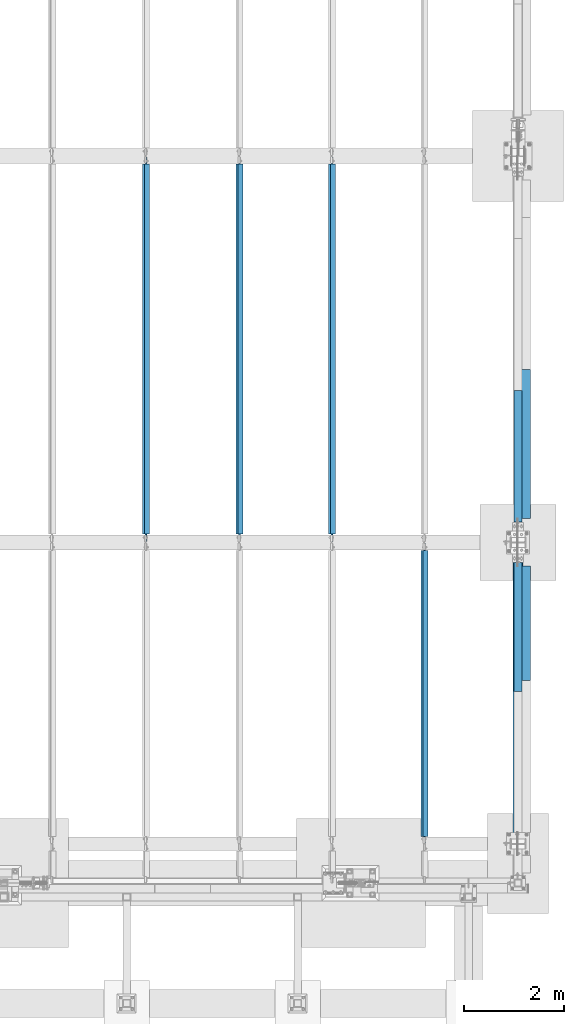
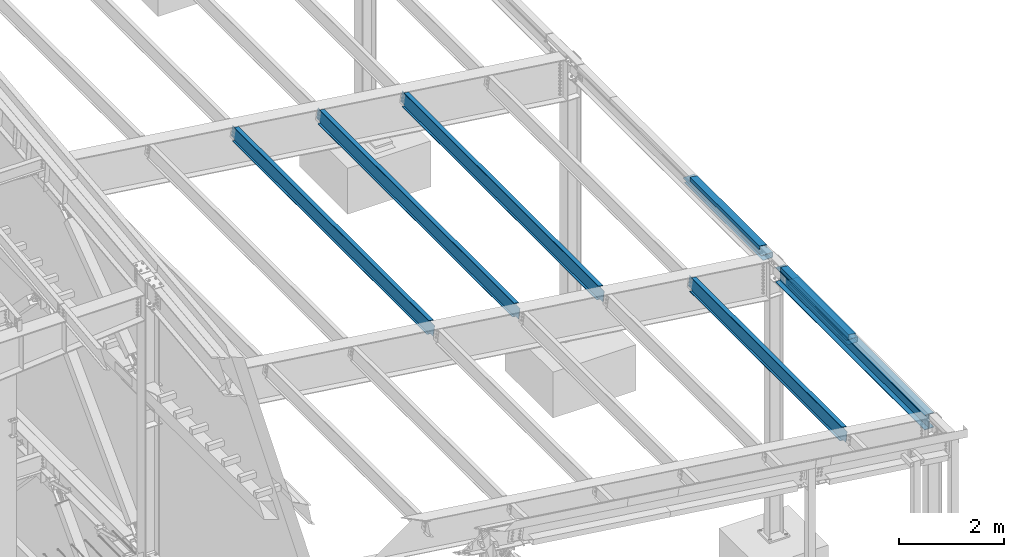
# One storey, part 748 of 1179: 9 beams, 6 elements without a shape of their own.
"""IFC2X3 building model written with IfcOpenShell, lengths in millimetres."""

from ifc_helpers import new_model, si_unit, frame, origin_with_axes, place, context, subcontext, project, spatial, faceted_brep, material, type_object, element, aggregate, save


model = new_model("IFC2X3")

# Units and contexts
model_context = context("Model", 3, precision=1e-05, world=origin_with_axes())
body_context = subcontext(model_context, "Body", "Model", "MODEL_VIEW")
ifc_project = project(units=[si_unit("LENGTHUNIT", "METRE", prefix="MILLI"), si_unit("AREAUNIT", "SQUARE_METRE"), si_unit("VOLUMEUNIT", "CUBIC_METRE"), si_unit("MASSUNIT", "GRAM", prefix="KILO"), si_unit("TIMEUNIT", "SECOND"), si_unit("PLANEANGLEUNIT", "RADIAN"), si_unit("SOLIDANGLEUNIT", "STERADIAN"), si_unit("THERMODYNAMICTEMPERATUREUNIT", "DEGREE_CELSIUS"), si_unit("LUMINOUSINTENSITYUNIT", "LUMEN")], contexts=[model_context])

# Site, building, storey
site_placement = place(None, origin_with_axes())
site = spatial("IfcSite", under=ifc_project, at=site_placement, CompositionType="ELEMENT")
building_placement = place(site_placement, origin_with_axes())
building = spatial("IfcBuilding", under=site, at=building_placement, Name="Undefined", CompositionType="ELEMENT")
storey_placement = place(building_placement, origin_with_axes())
storey = spatial("IfcBuildingStorey", under=building, at=storey_placement, Name="Undefined", CompositionType="ELEMENT", Elevation=0.0)

# Assembly, beam
assembly_1_placement = place(storey_placement, origin_with_axes())
assembly_1 = element("IfcElementAssembly", 1, at=assembly_1_placement, inside=storey, Name="BEAM", AssemblyPlace="NOTDEFINED", PredefinedType="RIGID_FRAME")
ifc_material_1 = material(Name="STEEL/A36")
beam_type_1 = type_object("IfcBeamType", PredefinedType="NOTDEFINED")
beam_1_placement = place(assembly_1_placement, frame((37996.8124994166, 13208.794, 6096.00000000004), z_axis=(0.0, -1.0, 0.0), x_axis=(0.0, 0.0, 1.0)))
beam_1 = element("IfcBeam", 2, at=beam_1_placement, type_object=beam_type_1, material=ifc_material_1, Name="BENT_PLATE", context=body_context, shape_type="Brep", body=[
    faceted_brep([(3.8198777474463e-11, -4.76249999999709, -1323.1815), (3.8198777474463e-11, -4.76249999999709, 1323.1815), (-3.8198777474463e-11, 4.76249999999709, 1323.1815), (-3.8198777474463e-11, 4.76249999999709, -1323.1815), (92.8848876952779, 4.76250000074651, 1323.1815), (92.8848876952779, 4.76250000074651, -1323.1815), (81.9873102930469, -4.76249999933498, -1323.1815), (81.9873102930469, -4.76249999933498, 1323.1815), (70.5918350219381, -160.337506103519, 1323.1815), (70.5918350219381, -160.337506103519, -1323.1815), (62.266532833075, -150.812506103524, -1323.1815), (62.266532833075, -150.812506103524, 1323.1815), (-7.6397554948926e-11, -160.337506103519, 1323.1815), (-7.6397554948926e-11, -160.337506103519, -1323.1815), (-7.6397554948926e-11, -150.812506103524, 1323.1815), (-7.6397554948926e-11, -150.812506103524, -1323.1815)], [[[0, 1, 2, 3]], [[3, 2, 4, 5]], [[1, 0, 6, 7]], [[5, 4, 8, 9]], [[7, 6, 10, 11]], [[9, 8, 12, 13]], [[8, 4, 2, 1, 7, 11, 14, 12]], [[11, 10, 15, 14]], [[10, 6, 0, 3, 5, 9, 13, 15]], [[14, 15, 13, 12]]]),
])

# Assembly, beams
assembly_2_placement = place(storey_placement, origin_with_axes())
assembly_2 = element("IfcElementAssembly", 3, at=assembly_2_placement, inside=storey, Name="BEAM", AssemblyPlace="NOTDEFINED", PredefinedType="RIGID_FRAME")
beam_2_placement = place(assembly_2_placement, frame((37996.8124994167, 9782.17499999974, 6096.00000000004), z_axis=(0.0, -1.0, 0.0), x_axis=(0.0, 0.0, 1.0)))
beam_2 = element("IfcBeam", 4, at=beam_2_placement, type_object=beam_type_1, material=ifc_material_1, Name="BENT_PLATE", context=body_context, shape_type="Brep", body=[
    faceted_brep([(3.8198777474463e-11, -4.76249999999709, -1295.4), (3.8198777474463e-11, -4.76249999999709, 1295.4), (-3.8198777474463e-11, 4.76249999999709, 1295.4), (-3.8198777474463e-11, 4.76249999999709, -1295.4), (92.8848876952779, 4.76250000074651, 1295.4), (92.8848876952779, 4.76250000074651, -1295.4), (81.9873102930469, -4.76249999933498, -1295.4), (81.9873102930469, -4.76249999933498, 1295.4), (70.5918350219381, -160.337506103519, 1295.4), (70.5918350219381, -160.337506103519, -1295.4), (62.266532833075, -150.812506103524, -1295.4), (62.266532833075, -150.812506103524, 1295.4), (-7.6397554948926e-11, -160.337506103519, 1295.4), (-7.6397554948926e-11, -160.337506103519, -1295.4), (-7.6397554948926e-11, -150.812506103524, 1295.4), (-7.6397554948926e-11, -150.812506103524, -1295.4)], [[[0, 1, 2, 3]], [[3, 2, 4, 5]], [[1, 0, 6, 7]], [[5, 4, 8, 9]], [[7, 6, 10, 11]], [[9, 8, 12, 13]], [[8, 4, 2, 1, 7, 11, 14, 12]], [[11, 10, 15, 14]], [[10, 6, 0, 3, 5, 9, 13, 15]], [[14, 15, 13, 12]]]),
])
beam_type_2 = type_object("IfcBeamType", PredefinedType="NOTDEFINED")
beam_3_placement = place(assembly_2_placement, frame((38112.7, 9859.16900000015, 5765.8), z_axis=(0.0, 1.0, 0.0), x_axis=(1.0, 0.0, 0.0)))
beam_3 = element("IfcBeam", 5, at=beam_3_placement, type_object=beam_type_2, material=ifc_material_1, Name="BENT_PLATE", context=body_context, shape_type="Brep", body=[
    faceted_brep([(0.0, -3.17500000000018, -1145.3815), (0.0, -3.17500000000018, 1145.3815), (0.0, 3.17500000000018, 1145.3815), (0.0, 3.17500000000018, -1145.3815), (215.900000000009, 3.17500000000018, 1145.3815), (215.900000000009, 3.17500000000018, -1145.3815), (209.550000000003, -3.17500000000018, -1145.3815), (209.550000000003, -3.17500000000018, 1145.3815), (215.900000000009, -123.825, 1145.3815), (215.900000000009, -123.825, -1145.3815), (209.550000000003, -117.474999999999, -1145.3815), (209.550000000003, -117.474999999999, 1145.3815), (-34.1312499999985, -123.825, 1145.3815), (-34.1312499999985, -123.825, -1145.3815), (-34.1312499999985, -117.474999999999, 1145.3815), (-34.1312499999985, -117.474999999999, -1145.3815)], [[[0, 1, 2, 3]], [[3, 2, 4, 5]], [[1, 0, 6, 7]], [[5, 4, 8, 9]], [[7, 6, 10, 11]], [[9, 8, 12, 13]], [[8, 4, 2, 1, 7, 11, 14, 12]], [[11, 10, 15, 14]], [[10, 6, 0, 3, 5, 9, 13, 15]], [[14, 15, 13, 12]]]),
])

# Beam
beam_4_placement = place(assembly_1_placement, frame((38112.7, 13454.0625000003, 5765.8), z_axis=(0.0, 1.0, 0.0), x_axis=(1.0, 0.0, 0.0)))
beam_4 = element("IfcBeam", 6, at=beam_4_placement, type_object=beam_type_2, material=ifc_material_1, Name="BENT_PLATE", context=body_context, shape_type="Brep", body=[
    faceted_brep([(0.0, -3.17500000000018, -1498.6), (0.0, -3.17500000000018, 1498.6), (0.0, 3.17500000000018, 1498.6), (0.0, 3.17500000000018, -1498.6), (215.900000000009, 3.17500000000018, 1498.6), (215.900000000009, 3.17500000000018, -1498.6), (209.550000000003, -3.17500000000018, -1498.6), (209.550000000003, -3.17500000000018, 1498.6), (215.900000000009, -123.825, 1498.6), (215.900000000009, -123.825, -1498.6), (209.550000000003, -117.474999999999, -1498.6), (209.550000000003, -117.474999999999, 1498.6), (-34.1312499999985, -123.825, 1498.6), (-34.1312499999985, -123.825, -1498.6), (-34.1312499999985, -117.474999999999, 1498.6), (-34.1312499999985, -117.474999999999, -1498.6)], [[[0, 1, 2, 3]], [[3, 2, 4, 5]], [[1, 0, 6, 7]], [[5, 4, 8, 9]], [[7, 6, 10, 11]], [[9, 8, 12, 13]], [[8, 4, 2, 1, 7, 11, 14, 12]], [[11, 10, 15, 14]], [[10, 6, 0, 3, 5, 9, 13, 15]], [[14, 15, 13, 12]]]),
])

aggregate(assembly_1, [beam_4, beam_1])

# Assembly, beam
assembly_3_placement = place(storey_placement, origin_with_axes())
assembly_3 = element("IfcElementAssembly", 7, at=assembly_3_placement, inside=storey, Name="BEAM", AssemblyPlace="NOTDEFINED", PredefinedType="RIGID_FRAME")
ifc_material_2 = material(Name="STEEL/A992")
beam_type_3 = type_object("IfcBeamType", Name="W12X22", PredefinedType="NOTDEFINED")
beam_5_placement = place(assembly_3_placement, frame((36199.5820076836, 5435.6, 6273.9306654382), z_axis=(0.133813223953133, 0.0, 0.991006569652931), x_axis=(0.0, 1.0, 0.0)))
beam_5 = element("IfcBeam", 8, at=beam_5_placement, type_object=beam_type_3, material=ifc_material_2, Name="BEAM", ObjectType="W12X22", context=body_context, shape_type="Brep", body=[
    faceted_brep([(5880.09999999999, -3.17499999983193, -144.462500000051), (5880.09999999999, -50.7999999998428, -144.462500000063), (5880.09999999999, -50.7999999998283, -155.575000000068), (5880.09999999999, 50.8000000001921, -155.575000000041), (5880.09999999999, 50.8000000001848, -144.462500000036), (5880.09999999999, 3.17500000017026, -144.462500000049), (5880.09999999999, 3.17500000016298, -136.52499982221), (5880.09999999999, -3.17499999983556, -136.524999822204), (5881.06672992258, 3.17500000015571, -131.66492030416), (5881.06672992258, -3.17499999984648, -131.664920304156), (5883.81974382306, 3.17500000015207, -127.544743836002), (5883.81974382306, -3.17499999985012, -127.544743835997), (5887.93992029121, 3.17500000014843, -124.791729935519), (5887.93992029121, -3.17499999985375, -124.791729935516), (5892.79999980926, 3.17500000014843, -123.825000012932), (5892.79999980926, -3.17499999985375, -123.825000012926), (6024.5625, -3.17499999985375, -123.825000012823), (6024.5625, 3.17500000014479, -123.825000012814), (144.4625, 3.17499999983193, 144.462500000049), (144.4625, 50.7999999998428, 144.462500000061), (5880.09999999999, 50.7999999998428, 144.462500000061), (5880.09999999999, 3.17499999983193, 144.462500000049), (146.049999999999, -3.1749999998392, -136.524999805057), (146.049999999999, 3.17500000015934, -136.52499980506), (146.049999999999, 3.17500000017026, -144.462500000049), (146.049999999999, 50.8000000001848, -144.462500000036), (146.049999999999, 50.8000000001921, -155.575000000041), (146.049999999999, -50.7999999998283, -155.575000000068), (146.049999999999, -50.7999999998428, -144.462500000063), (146.049999999999, -3.17499999983193, -144.462500000051), (145.083270077412, -3.17499999984284, -131.664920287005), (145.083270077412, 3.17500000015571, -131.664920287008), (142.330256176933, -3.17499999985012, -127.544743818849), (142.330256176933, 3.17500000015207, -127.544743818851), (138.21007970878, -3.17499999985375, -124.791729918366), (138.21007970878, 3.17500000014479, -124.791729918372), (133.350000190734, -3.17499999985375, -123.824999995779), (133.350000190734, 3.17500000014843, -123.824999995781), (19.0500000000002, -3.17499999985375, -123.824999995893), (19.0500000000002, 3.17500000014843, -123.824999995886), (19.0500000000002, -3.17500000013752, 117.475000004351), (19.0500000000002, 3.17499999986467, 117.475000004359), (131.762500190734, -3.17500000013752, 117.47500000447), (131.762500190734, 3.17499999986467, 117.475000004464), (136.62257970878, -3.17500000013752, 118.441729927057), (136.62257970878, 3.17499999986103, 118.441729927054), (140.742756176934, -3.17500000014115, 121.194743827538), (140.742756176934, 3.17499999986103, 121.194743827535), (143.495770077412, -3.17500000014479, 125.314920295696), (143.495770077412, 3.17499999985375, 125.314920295692), (144.4625, -3.17500000015571, 130.174999813746), (144.4625, 3.17499999984648, 130.174999813742), (144.4625, -50.8000000001921, 155.575000000039), (144.4625, 50.7999999998283, 155.575000000066), (144.4625, -3.17500000016662, 144.462500000047), (144.4625, -50.8000000001812, 144.462500000034), (5880.09999999999, -3.17500000016662, 144.462500000047), (5880.09999999999, -50.8000000001812, 144.462500000034), (5880.09999999999, -50.8000000001921, 155.575000000039), (5880.09999999999, 50.7999999998283, 155.575000000066), (5880.09999999999, -3.17500000015207, 130.17499979644), (5880.09999999999, 3.17499999985012, 130.174999796436), (5881.06672992258, -3.17500000014843, 125.314920278392), (5881.06672992258, 3.17499999985012, 125.314920278386), (5883.81974382306, -3.17500000014479, 121.194743810232), (5883.81974382306, 3.17499999985739, 121.194743810229), (5887.93992029121, -3.17500000013752, 118.441729909751), (5887.93992029121, 3.17499999986103, 118.441729909748), (5892.79999980926, -3.17500000013752, 117.474999987164), (5892.79999980926, 3.17499999986467, 117.474999987158), (6024.5625, -3.17500000013752, 117.474999987267), (6024.5625, 3.17499999986467, 117.474999987275)], [[[0, 1, 2, 3, 4, 5, 6, 7]], [[7, 6, 8, 9]], [[9, 8, 10, 11]], [[11, 10, 12, 13]], [[13, 12, 14, 15]], [[16, 15, 14, 17]], [[18, 19, 20, 21]], [[22, 23, 24, 25, 26, 27, 28, 29]], [[30, 31, 23, 22]], [[32, 33, 31, 30]], [[34, 35, 33, 32]], [[36, 37, 35, 34]], [[38, 39, 37, 36]], [[40, 41, 39, 38]], [[42, 43, 41, 40]], [[44, 45, 43, 42]], [[46, 47, 45, 44]], [[48, 49, 47, 46]], [[50, 51, 49, 48]], [[52, 53, 19, 18, 51, 50, 54, 55]], [[55, 54, 56, 57]], [[52, 55, 57, 58]], [[53, 52, 58, 59]], [[19, 53, 59, 20]], [[58, 57, 56, 60, 61, 21, 20, 59]], [[62, 63, 61, 60]], [[64, 65, 63, 62]], [[66, 67, 65, 64]], [[68, 69, 67, 66]], [[70, 71, 69, 68]], [[71, 70, 16, 17]], [[12, 10, 8, 6, 5, 24, 23, 31, 33, 35, 37, 39, 41, 43, 45, 47, 49, 51, 18, 21, 61, 63, 65, 67, 69, 71, 17, 14]], [[25, 24, 5, 4]], [[26, 25, 4, 3]], [[27, 26, 3, 2]], [[28, 27, 2, 1]], [[29, 28, 1, 0]], [[70, 68, 66, 64, 62, 60, 56, 54, 50, 48, 46, 44, 42, 40, 38, 36, 34, 32, 30, 22, 29, 0, 7, 9, 11, 13, 15, 16]]]),
])
aggregate(assembly_3, [beam_5])

assembly_4_placement = place(storey_placement, origin_with_axes())
assembly_4 = element("IfcElementAssembly", 9, at=assembly_4_placement, inside=storey, Name="BEAM", AssemblyPlace="NOTDEFINED", PredefinedType="RIGID_FRAME")
beam_6_placement = place(assembly_4_placement, frame((34345.3820076476, 11480.8, 6524.29881517188), z_axis=(0.133813223953133, 0.0, 0.991006569652931), x_axis=(0.0, 1.0, 0.0)))
beam_6 = element("IfcBeam", 10, at=beam_6_placement, type_object=beam_type_3, material=ifc_material_2, Name="BEAM", ObjectType="W12X22", context=body_context, shape_type="Brep", body=[
    faceted_brep([(7585.075, -3.17499999982829, -144.462500000047), (7585.075, -50.7999999998428, -144.46250000006), (7585.075, -50.7999999998356, -155.575000000064), (7585.075, 50.8000000001921, -155.575000000037), (7585.075, 50.8000000001775, -144.462500000032), (7585.075, 3.17500000017026, -144.462500000047), (7585.075, 3.17500000016298, -136.524999801413), (7585.075, -3.17499999984284, -136.52499980141), (7586.04172992259, 3.17500000014843, -131.664920283363), (7586.04172992259, -3.17499999984284, -131.66492028336), (7588.79474382307, 3.17500000014843, -127.544743815206), (7588.79474382307, -3.17499999985012, -127.544743815202), (7592.91492029122, 3.17500000014843, -124.791729914725), (7592.91492029122, -3.17499999985012, -124.791729914721), (7597.77499980927, 3.17500000014115, -123.824999992135), (7597.77499980927, -3.17499999985739, -123.824999992132), (7726.3625, -3.17499999985739, -123.824999992028), (7726.3625, 3.17500000014115, -123.824999992019), (165.100000000002, 3.17499999982829, 144.462500000052), (165.100000000002, 50.7999999998356, 144.462500000065), (7585.075, 50.7999999998356, 144.462500000065), (7585.075, 3.17499999982829, 144.462500000052), (165.100000000002, -3.17499999984284, -136.524999799762), (165.100000000002, 3.17500000016298, -136.524999799765), (165.100000000002, 3.17500000017026, -144.462500000047), (165.100000000002, 50.8000000001775, -144.462500000032), (165.100000000002, 50.8000000001921, -155.575000000037), (165.100000000002, -50.7999999998356, -155.575000000064), (165.100000000002, -50.7999999998428, -144.46250000006), (165.100000000002, -3.17499999982829, -144.462500000047), (164.133270077415, -3.17499999984284, -131.664920281712), (164.133270077415, 3.17500000014843, -131.664920281715), (161.380256176937, -3.17499999985739, -127.544743813552), (161.380256176937, 3.17500000014843, -127.544743813558), (157.260079708783, -3.17499999985739, -124.791729913073), (157.260079708783, 3.17500000014115, -124.791729913077), (152.400000190737, -3.17499999985739, -123.824999990484), (152.400000190737, 3.17500000014843, -123.824999990487), (20.6375000000044, -3.17499999985739, -123.824999990466), (20.6375000000044, 3.17500000014843, -123.824999990458), (20.6375000000044, -3.17500000014115, 117.475000009781), (20.6375000000044, 3.17499999986467, 117.475000009788), (152.400000190737, -3.17500000014115, 117.475000009763), (152.400000190737, 3.17499999985739, 117.475000009759), (157.260079708783, -3.17500000014115, 118.44172993235), (157.260079708783, 3.17499999986467, 118.441729932347), (161.380256176937, -3.17500000014115, 121.194743832832), (161.380256176937, 3.17499999985739, 121.194743832826), (164.133270077415, -3.17500000014843, 125.314920300991), (164.133270077415, 3.17499999985012, 125.314920300985), (165.100000000002, -3.17500000016298, 130.174999819041), (165.100000000002, 3.17499999984284, 130.174999819037), (165.100000000002, -50.8000000001994, 155.575000000043), (165.100000000002, 50.7999999998283, 155.57500000007), (165.100000000002, -3.17500000017753, 144.462500000051), (165.100000000002, -50.8000000001775, 144.462500000036), (7585.075, -3.17500000017753, 144.462500000051), (7585.075, -50.8000000001775, 144.462500000036), (7585.075, -50.8000000001994, 155.575000000043), (7585.075, 50.7999999998283, 155.57500000007), (7585.075, -3.17500000015571, 130.174999817393), (7585.075, 3.17499999985012, 130.174999817389), (7586.04172992259, -3.17500000015571, 125.314920299345), (7586.04172992259, 3.17499999985012, 125.314920299339), (7588.79474382307, -3.17500000014843, 121.194743831185), (7588.79474382307, 3.17499999985739, 121.194743831182), (7592.91492029122, -3.17500000014115, 118.441729930704), (7592.91492029122, 3.17499999986467, 118.441729930701), (7597.77499980927, -3.17500000014115, 117.475000008117), (7597.77499980927, 3.17499999986467, 117.475000008111), (7726.3625, -3.17500000014115, 117.47500000822), (7726.3625, 3.17499999985739, 117.475000008229)], [[[0, 1, 2, 3, 4, 5, 6, 7]], [[7, 6, 8, 9]], [[9, 8, 10, 11]], [[11, 10, 12, 13]], [[13, 12, 14, 15]], [[16, 15, 14, 17]], [[18, 19, 20, 21]], [[22, 23, 24, 25, 26, 27, 28, 29]], [[30, 31, 23, 22]], [[32, 33, 31, 30]], [[34, 35, 33, 32]], [[36, 37, 35, 34]], [[38, 39, 37, 36]], [[40, 41, 39, 38]], [[42, 43, 41, 40]], [[44, 45, 43, 42]], [[46, 47, 45, 44]], [[48, 49, 47, 46]], [[50, 51, 49, 48]], [[52, 53, 19, 18, 51, 50, 54, 55]], [[55, 54, 56, 57]], [[52, 55, 57, 58]], [[53, 52, 58, 59]], [[19, 53, 59, 20]], [[58, 57, 56, 60, 61, 21, 20, 59]], [[62, 63, 61, 60]], [[64, 65, 63, 62]], [[66, 67, 65, 64]], [[68, 69, 67, 66]], [[70, 71, 69, 68]], [[71, 70, 16, 17]], [[12, 10, 8, 6, 5, 24, 23, 31, 33, 35, 37, 39, 41, 43, 45, 47, 49, 51, 18, 21, 61, 63, 65, 67, 69, 71, 17, 14]], [[25, 24, 5, 4]], [[26, 25, 4, 3]], [[27, 26, 3, 2]], [[28, 27, 2, 1]], [[29, 28, 1, 0]], [[70, 68, 66, 64, 62, 60, 56, 54, 50, 48, 46, 44, 42, 40, 38, 36, 34, 32, 30, 22, 29, 0, 7, 9, 11, 13, 15, 16]]]),
])
aggregate(assembly_4, [beam_6])

assembly_5_placement = place(storey_placement, origin_with_axes())
assembly_5 = element("IfcElementAssembly", 11, at=assembly_5_placement, inside=storey, Name="BEAM", AssemblyPlace="NOTDEFINED", PredefinedType="RIGID_FRAME")
beam_7_placement = place(assembly_5_placement, frame((32491.1820076481, 11480.8, 6774.66696326265), z_axis=(0.133813223953133, 0.0, 0.991006569652931), x_axis=(0.0, 1.0, 0.0)))
beam_7 = element("IfcBeam", 12, at=beam_7_placement, type_object=beam_type_3, material=ifc_material_2, Name="BEAM", ObjectType="W12X22", context=body_context, shape_type="Brep", body=[
    faceted_brep([(7585.075, -3.17499999982829, -144.462500000047), (7585.075, -50.7999999998428, -144.46250000006), (7585.075, -50.7999999998356, -155.575000000064), (7585.075, 50.8000000001921, -155.575000000037), (7585.075, 50.8000000001775, -144.462500000032), (7585.075, 3.17500000017026, -144.462500000047), (7585.075, 3.17500000016298, -136.524999801413), (7585.075, -3.17499999984284, -136.52499980141), (7586.04172992259, 3.17500000014843, -131.664920283363), (7586.04172992259, -3.17499999984284, -131.66492028336), (7588.79474382307, 3.17500000014843, -127.544743815206), (7588.79474382307, -3.17499999985012, -127.544743815202), (7592.91492029122, 3.17500000014843, -124.791729914725), (7592.91492029122, -3.17499999985012, -124.791729914721), (7597.77499980927, 3.17500000014115, -123.824999992135), (7597.77499980927, -3.17499999985739, -123.824999992132), (7726.3625, -3.17499999985739, -123.824999992028), (7726.3625, 3.17500000014115, -123.824999992019), (165.100000000002, 3.17499999982829, 144.462500000052), (165.100000000002, 50.7999999998356, 144.462500000065), (7585.075, 50.7999999998356, 144.462500000065), (7585.075, 3.17499999982829, 144.462500000052), (165.100000000002, -3.17499999984284, -136.524999799762), (165.100000000002, 3.17500000016298, -136.524999799765), (165.100000000002, 3.17500000017026, -144.462500000047), (165.100000000002, 50.8000000001775, -144.462500000032), (165.100000000002, 50.8000000001921, -155.575000000037), (165.100000000002, -50.7999999998356, -155.575000000064), (165.100000000002, -50.7999999998428, -144.46250000006), (165.100000000002, -3.17499999982829, -144.462500000047), (164.133270077415, -3.17499999984284, -131.664920281712), (164.133270077415, 3.17500000014843, -131.664920281715), (161.380256176937, -3.17499999985739, -127.544743813552), (161.380256176937, 3.17500000014843, -127.544743813558), (157.260079708783, -3.17499999985739, -124.791729913073), (157.260079708783, 3.17500000014115, -124.791729913077), (152.400000190737, -3.17499999985739, -123.824999990484), (152.400000190737, 3.17500000014843, -123.824999990487), (20.6375000000044, -3.17499999985739, -123.824999990466), (20.6375000000044, 3.17500000014843, -123.824999990458), (20.6375000000044, -3.17500000014115, 117.475000009781), (20.6375000000044, 3.17499999986467, 117.475000009788), (152.400000190737, -3.17500000014115, 117.475000009763), (152.400000190737, 3.17499999985739, 117.475000009759), (157.260079708783, -3.17500000014115, 118.44172993235), (157.260079708783, 3.17499999986467, 118.441729932347), (161.380256176937, -3.17500000014115, 121.194743832832), (161.380256176937, 3.17499999985739, 121.194743832826), (164.133270077415, -3.17500000014843, 125.314920300991), (164.133270077415, 3.17499999985012, 125.314920300985), (165.100000000002, -3.17500000016298, 130.174999819041), (165.100000000002, 3.17499999984284, 130.174999819037), (165.100000000002, -50.8000000001994, 155.575000000043), (165.100000000002, 50.7999999998283, 155.57500000007), (165.100000000002, -3.17500000017753, 144.462500000051), (165.100000000002, -50.8000000001775, 144.462500000036), (7585.075, -3.17500000017753, 144.462500000051), (7585.075, -50.8000000001775, 144.462500000036), (7585.075, -50.8000000001994, 155.575000000043), (7585.075, 50.7999999998283, 155.57500000007), (7585.075, -3.17500000015571, 130.174999817393), (7585.075, 3.17499999985012, 130.174999817389), (7586.04172992259, -3.17500000015571, 125.314920299345), (7586.04172992259, 3.17499999985012, 125.314920299339), (7588.79474382307, -3.17500000014843, 121.194743831185), (7588.79474382307, 3.17499999985739, 121.194743831182), (7592.91492029122, -3.17500000014115, 118.441729930704), (7592.91492029122, 3.17499999986467, 118.441729930701), (7597.77499980927, -3.17500000014115, 117.475000008117), (7597.77499980927, 3.17499999986467, 117.475000008111), (7726.3625, -3.17500000014115, 117.47500000822), (7726.3625, 3.17499999985739, 117.475000008229)], [[[0, 1, 2, 3, 4, 5, 6, 7]], [[7, 6, 8, 9]], [[9, 8, 10, 11]], [[11, 10, 12, 13]], [[13, 12, 14, 15]], [[16, 15, 14, 17]], [[18, 19, 20, 21]], [[22, 23, 24, 25, 26, 27, 28, 29]], [[30, 31, 23, 22]], [[32, 33, 31, 30]], [[34, 35, 33, 32]], [[36, 37, 35, 34]], [[38, 39, 37, 36]], [[40, 41, 39, 38]], [[42, 43, 41, 40]], [[44, 45, 43, 42]], [[46, 47, 45, 44]], [[48, 49, 47, 46]], [[50, 51, 49, 48]], [[52, 53, 19, 18, 51, 50, 54, 55]], [[55, 54, 56, 57]], [[52, 55, 57, 58]], [[53, 52, 58, 59]], [[19, 53, 59, 20]], [[58, 57, 56, 60, 61, 21, 20, 59]], [[62, 63, 61, 60]], [[64, 65, 63, 62]], [[66, 67, 65, 64]], [[68, 69, 67, 66]], [[70, 71, 69, 68]], [[71, 70, 16, 17]], [[12, 10, 8, 6, 5, 24, 23, 31, 33, 35, 37, 39, 41, 43, 45, 47, 49, 51, 18, 21, 61, 63, 65, 67, 69, 71, 17, 14]], [[25, 24, 5, 4]], [[26, 25, 4, 3]], [[27, 26, 3, 2]], [[28, 27, 2, 1]], [[29, 28, 1, 0]], [[70, 68, 66, 64, 62, 60, 56, 54, 50, 48, 46, 44, 42, 40, 38, 36, 34, 32, 30, 22, 29, 0, 7, 9, 11, 13, 15, 16]]]),
])
aggregate(assembly_5, [beam_7])

assembly_6_placement = place(storey_placement, origin_with_axes())
assembly_6 = element("IfcElementAssembly", 13, at=assembly_6_placement, inside=storey, Name="BEAM", AssemblyPlace="NOTDEFINED", PredefinedType="RIGID_FRAME")
beam_8_placement = place(assembly_6_placement, frame((30611.5820076509, 11480.8, 7028.4648120121), z_axis=(0.133813223953133, 0.0, 0.991006569652931), x_axis=(0.0, 1.0, 0.0)))
beam_8 = element("IfcBeam", 14, at=beam_8_placement, type_object=beam_type_3, material=ifc_material_2, Name="BEAM", ObjectType="W12X22", context=body_context, shape_type="Brep", body=[
    faceted_brep([(7585.075, -3.17499999982829, -144.462500000047), (7585.075, -50.7999999998428, -144.46250000006), (7585.075, -50.7999999998356, -155.575000000064), (7585.075, 50.8000000001921, -155.575000000037), (7585.075, 50.8000000001775, -144.462500000032), (7585.075, 3.17500000017026, -144.462500000047), (7585.075, 3.17500000016298, -136.524999801413), (7585.075, -3.17499999984284, -136.52499980141), (7586.04172992259, 3.17500000014843, -131.664920283363), (7586.04172992259, -3.17499999984284, -131.66492028336), (7588.79474382307, 3.17500000014843, -127.544743815206), (7588.79474382307, -3.17499999985012, -127.544743815202), (7592.91492029122, 3.17500000014843, -124.791729914725), (7592.91492029122, -3.17499999985012, -124.791729914721), (7597.77499980927, 3.17500000014115, -123.824999992135), (7597.77499980927, -3.17499999985739, -123.824999992132), (7726.3625, -3.17499999985739, -123.824999992028), (7726.3625, 3.17500000014115, -123.824999992019), (165.100000000002, 3.17499999982829, 144.462500000052), (165.100000000002, 50.7999999998356, 144.462500000065), (7585.075, 50.7999999998356, 144.462500000065), (7585.075, 3.17499999982829, 144.462500000052), (165.100000000002, -3.17499999984284, -136.524999799762), (165.100000000002, 3.17500000016298, -136.524999799765), (165.100000000002, 3.17500000017026, -144.462500000047), (165.100000000002, 50.8000000001775, -144.462500000032), (165.100000000002, 50.8000000001921, -155.575000000037), (165.100000000002, -50.7999999998356, -155.575000000064), (165.100000000002, -50.7999999998428, -144.46250000006), (165.100000000002, -3.17499999982829, -144.462500000047), (164.133270077415, -3.17499999984284, -131.664920281712), (164.133270077415, 3.17500000014843, -131.664920281715), (161.380256176937, -3.17499999985739, -127.544743813552), (161.380256176937, 3.17500000014843, -127.544743813558), (157.260079708783, -3.17499999985739, -124.791729913073), (157.260079708783, 3.17500000014115, -124.791729913077), (152.400000190737, -3.17499999985739, -123.824999990484), (152.400000190737, 3.17500000014843, -123.824999990487), (20.6375000000044, -3.17499999985739, -123.824999990466), (20.6375000000044, 3.17500000014843, -123.824999990458), (20.6375000000044, -3.17500000014115, 117.475000009781), (20.6375000000044, 3.17499999986467, 117.475000009788), (152.400000190737, -3.17500000014115, 117.475000009763), (152.400000190737, 3.17499999985739, 117.475000009759), (157.260079708783, -3.17500000014115, 118.44172993235), (157.260079708783, 3.17499999986467, 118.441729932347), (161.380256176937, -3.17500000014115, 121.194743832832), (161.380256176937, 3.17499999985739, 121.194743832826), (164.133270077415, -3.17500000014843, 125.314920300991), (164.133270077415, 3.17499999985012, 125.314920300985), (165.100000000002, -3.17500000016298, 130.174999819041), (165.100000000002, 3.17499999984284, 130.174999819037), (165.100000000002, -50.8000000001994, 155.575000000043), (165.100000000002, 50.7999999998283, 155.57500000007), (165.100000000002, -3.17500000017753, 144.462500000051), (165.100000000002, -50.8000000001775, 144.462500000036), (7585.075, -3.17500000017753, 144.462500000051), (7585.075, -50.8000000001775, 144.462500000036), (7585.075, -50.8000000001994, 155.575000000043), (7585.075, 50.7999999998283, 155.57500000007), (7585.075, -3.17500000015571, 130.174999817393), (7585.075, 3.17499999985012, 130.174999817389), (7586.04172992259, -3.17500000015571, 125.314920299345), (7586.04172992259, 3.17499999985012, 125.314920299339), (7588.79474382307, -3.17500000014843, 121.194743831185), (7588.79474382307, 3.17499999985739, 121.194743831182), (7592.91492029122, -3.17500000014115, 118.441729930704), (7592.91492029122, 3.17499999986467, 118.441729930701), (7597.77499980927, -3.17500000014115, 117.475000008117), (7597.77499980927, 3.17499999986467, 117.475000008111), (7726.3625, -3.17500000014115, 117.47500000822), (7726.3625, 3.17499999985739, 117.475000008229)], [[[0, 1, 2, 3, 4, 5, 6, 7]], [[7, 6, 8, 9]], [[9, 8, 10, 11]], [[11, 10, 12, 13]], [[13, 12, 14, 15]], [[16, 15, 14, 17]], [[18, 19, 20, 21]], [[22, 23, 24, 25, 26, 27, 28, 29]], [[30, 31, 23, 22]], [[32, 33, 31, 30]], [[34, 35, 33, 32]], [[36, 37, 35, 34]], [[38, 39, 37, 36]], [[40, 41, 39, 38]], [[42, 43, 41, 40]], [[44, 45, 43, 42]], [[46, 47, 45, 44]], [[48, 49, 47, 46]], [[50, 51, 49, 48]], [[52, 53, 19, 18, 51, 50, 54, 55]], [[55, 54, 56, 57]], [[52, 55, 57, 58]], [[53, 52, 58, 59]], [[19, 53, 59, 20]], [[58, 57, 56, 60, 61, 21, 20, 59]], [[62, 63, 61, 60]], [[64, 65, 63, 62]], [[66, 67, 65, 64]], [[68, 69, 67, 66]], [[70, 71, 69, 68]], [[71, 70, 16, 17]], [[12, 10, 8, 6, 5, 24, 23, 31, 33, 35, 37, 39, 41, 43, 45, 47, 49, 51, 18, 21, 61, 63, 65, 67, 69, 71, 17, 14]], [[25, 24, 5, 4]], [[26, 25, 4, 3]], [[27, 26, 3, 2]], [[28, 27, 2, 1]], [[29, 28, 1, 0]], [[70, 68, 66, 64, 62, 60, 56, 54, 50, 48, 46, 44, 42, 40, 38, 36, 34, 32, 30, 22, 29, 0, 7, 9, 11, 13, 15, 16]]]),
])
aggregate(assembly_6, [beam_8])

# Beam
beam_type_4 = type_object("IfcBeamType", Name="W14X48", PredefinedType="NOTDEFINED")
beam_9_placement = place(assembly_2_placement, frame((38074.6, 5435.6, 5921.375), z_axis=(0.0, 0.0, 1.0), x_axis=(0.0, 1.0, 0.0)))
beam_9 = element("IfcBeam", 15, at=beam_9_placement, type_object=beam_type_4, material=ifc_material_2, Name="BEAM", ObjectType="W14X48", context=body_context, shape_type="Brep", body=[
    faceted_brep([(115.887499999999, -101.599999999999, -174.625), (115.887499999999, 101.599999999999, -174.625), (5799.1375, 101.599999999999, -174.625), (5799.1375, -101.599999999999, -174.625), (115.887499999999, -101.599999999999, -158.75), (115.887499999999, -3.96875, -158.75), (115.887499999999, -3.96875, 158.75), (115.887499999999, -101.599999999999, 158.75), (115.887499999999, -101.599999999999, 174.625), (115.887499999999, 101.599999999999, 174.625), (115.887499999999, 101.599999999999, 158.75), (115.887499999999, 3.96875, 158.75), (115.887499999999, 3.96875, 137.265000000093), (115.887499999999, 3.96875, -92.8149999999832), (115.887499999999, 3.96875, -158.75), (115.887499999999, 101.599999999999, -158.75), (5799.1375, -101.599999999999, -158.75), (5799.1375, -3.96875, -158.75), (5799.1375, -3.96875, 158.75), (5799.1375, -101.599999999999, 158.75), (5799.1375, -101.599999999999, 174.625), (5799.1375, 101.599999999999, 174.625), (5799.1375, 101.599999999999, 158.75), (5799.1375, 3.96875, 158.75), (5799.1375, 3.96875, 124.565000000088), (5799.1375, 3.96875, -105.514999999989), (5799.1375, 3.96875, -158.75), (5799.1375, 101.599999999999, -158.75)], [[[0, 1, 2, 3]], [[0, 4, 5, 6, 7, 8, 9, 10, 11, 12, 13, 14, 15, 1]], [[5, 4, 16, 17]], [[6, 5, 17, 18]], [[7, 6, 18, 19]], [[8, 7, 19, 20]], [[9, 8, 20, 21]], [[10, 9, 21, 22]], [[11, 10, 22, 23]], [[14, 13, 12, 11, 23, 24, 25, 26]], [[15, 14, 26, 27]], [[1, 15, 27, 2]], [[26, 25, 24, 23, 22, 21, 20, 19, 18, 17, 16, 3, 2, 27]], [[4, 0, 3, 16]]]),
])

aggregate(assembly_2, [beam_3, beam_2, beam_9])

save(model, "model.ifc")
